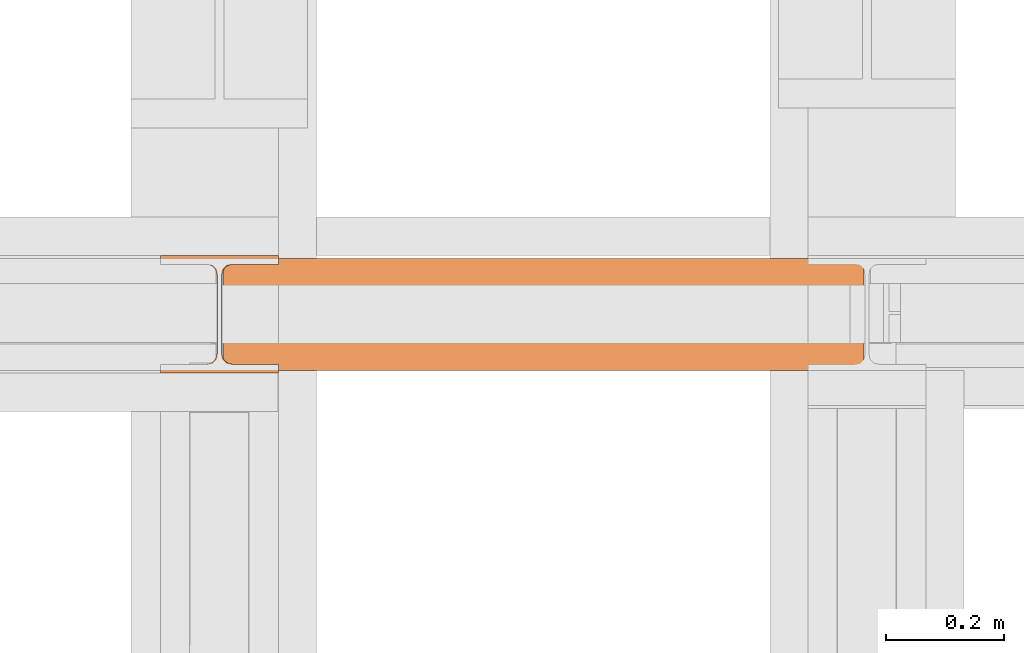
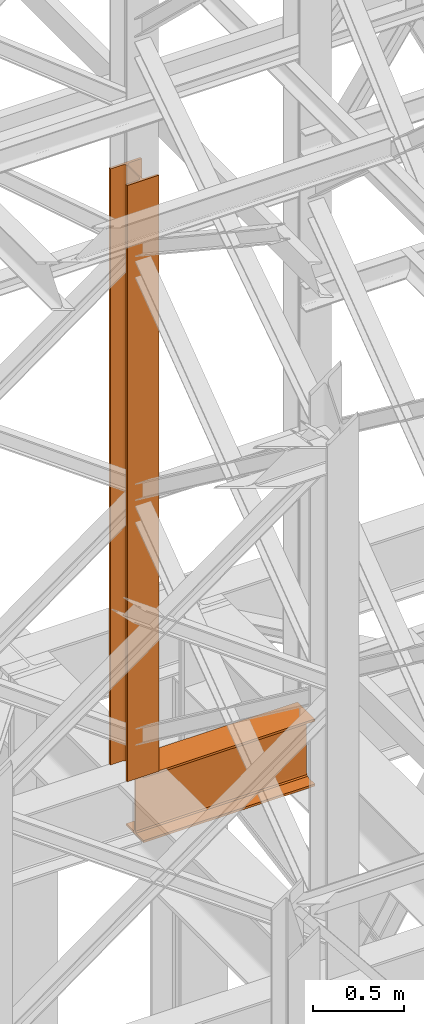
# One storey, part 129 of 208: 2 proxies.
"""IFC2X3 building model written with IfcOpenShell, lengths in millimetres."""

import ifcopenshell
import ifcopenshell.guid

model = None  # the IFC model being written
_history = None  # IfcOwnerHistory: only IFC2X3 demands one
_inside = {}  # id of a spatial element -> (the spatial element, [elements in it])
_under = {}  # id of a project, library or spatial element -> (it, [spatial elements below it])
_declared = {}  # id of a project -> (the project, [libraries it declares])
_typed = {}  # id of a type object -> (the type object, [elements of that type])
_made_of = {}  # id of a material, layer set ... -> (it, [elements and type objects made of it])


def new_model(schema):
    """Start an empty IFC model of exactly this schema.

    Asked for "IFC4X3", IfcOpenShell would pick the latest addendum, in which some entities
    have other attributes; the version numbers below select the first issue.
    IFC2X3 requires an IfcOwnerHistory on every rooted entity: one is made here for all.
    """
    global model, _history
    if schema == "IFC4X3":
        model = ifcopenshell.file(schema_version=(4, 3, 0, 0))
    else:
        model = ifcopenshell.file(schema=schema)
    _inside.clear()
    _under.clear()
    _declared.clear()
    _typed.clear()
    _made_of.clear()
    _history = None
    if model.schema == "IFC2X3":
        org = make("IfcOrganization", Name="unknown")
        user = make(
            "IfcPersonAndOrganization",
            ThePerson=make("IfcPerson", FamilyName="unknown"),
            TheOrganization=org,
        )
        app = make(
            "IfcApplication",
            ApplicationDeveloper=org,
            Version="unknown",
            ApplicationFullName="unknown",
            ApplicationIdentifier="unknown",
        )
        _history = make(
            "IfcOwnerHistory",
            OwningUser=user,
            OwningApplication=app,
            ChangeAction="ADDED",
            CreationDate=0,
        )
    return model


def make(cls, **values):
    """One entity of the class cls with the attributes given. An attribute that is None is left unset."""
    return model.create_entity(
        cls, **{name: value for name, value in values.items() if value is not None}
    )


def entity(cls, *values):
    """Any entity or typed value of the class cls, its attributes in the order of the schema. None: left unset."""
    e = model.create_entity(cls)
    for i, value in enumerate(values):
        if value is not None:
            e[i] = value
    return e


def rooted(cls, **values):
    """An entity with a GlobalId (a new one), such as an element, a storey or a relation."""
    return make(cls, GlobalId=ifcopenshell.guid.new(), OwnerHistory=_history, **values)


def si_unit(unit_type, name, prefix=None):
    """IfcSIUnit, for example si_unit("LENGTHUNIT", "METRE", prefix="MILLI")."""
    return make("IfcSIUnit", UnitType=unit_type, Prefix=prefix, Name=name)


def converted_unit(unit_type, name, factor, base, dimensions=None, offset=None):
    """IfcConversionBasedUnit, such as the inch: factor (a typed value) times the base unit."""
    return make(
        "IfcConversionBasedUnit"
        if offset is None
        else "IfcConversionBasedUnitWithOffset",
        ConversionOffset=offset,
        Dimensions=None
        if dimensions is None
        else entity("IfcDimensionalExponents", *dimensions),
        UnitType=unit_type,
        Name=name,
        ConversionFactor=make(
            "IfcMeasureWithUnit", ValueComponent=factor, UnitComponent=base
        ),
    )


def assignment(units):
    """IfcUnitAssignment: the units of a project."""
    return None if units is None else make("IfcUnitAssignment", Units=units)


def point(xyz):
    """IfcCartesianPoint."""
    return None if xyz is None else make("IfcCartesianPoint", Coordinates=xyz)


def direction(xyz):
    """IfcDirection."""
    return None if xyz is None else make("IfcDirection", DirectionRatios=xyz)


def frame(location, z_axis=None, x_axis=None):
    """IfcAxis2Placement3D, a coordinate frame: its origin and axes. An axis left out is left unset."""
    return make(
        "IfcAxis2Placement3D",
        Location=point(location),
        Axis=direction(z_axis),
        RefDirection=direction(x_axis),
    )


def origin():
    """The frame at (0, 0, 0) with its axes left unset."""
    return frame((0.0, 0.0, 0.0))


def origin_with_axes():
    """The frame at (0, 0, 0) with the z axis (0, 0, 1) and the x axis (1, 0, 0) written out."""
    return frame((0.0, 0.0, 0.0), z_axis=(0.0, 0.0, 1.0), x_axis=(1.0, 0.0, 0.0))


def place(relative_to, where):
    """IfcLocalPlacement: puts the frame where relative to a parent placement (None: the world)."""
    return make(
        "IfcLocalPlacement", PlacementRelTo=relative_to, RelativePlacement=where
    )


def context(
    kind, dimensions, precision=None, world=None, true_north=None, identifier=None
):
    """IfcGeometricRepresentationContext, for example the 3D "Model" context."""
    return make(
        "IfcGeometricRepresentationContext",
        ContextIdentifier=identifier,
        ContextType=kind,
        CoordinateSpaceDimension=dimensions,
        Precision=precision,
        WorldCoordinateSystem=world,
        TrueNorth=true_north,
    )


def subcontext(parent, identifier, kind, view, scale=None):
    """IfcGeometricRepresentationSubContext, for example "Body" below "Model"."""
    return make(
        "IfcGeometricRepresentationSubContext",
        ContextIdentifier=identifier,
        ContextType=kind,
        ParentContext=parent,
        TargetScale=scale,
        TargetView=view,
    )


def project(units=None, contexts=None):
    """IfcProject with its units and contexts."""
    return rooted(
        "IfcProject",
        Name="project",
        RepresentationContexts=contexts,
        UnitsInContext=assignment(units),
    )


def spatial(cls, under=None, at=None, **own):
    """A site, building, storey or space (cls), placed at a placement, below another one or the project."""
    s = rooted(cls, ObjectPlacement=at, **own)
    if under is not None:
        _under.setdefault(under.id(), (under, []))[1].append(s)
    return s


def faces_of(points, faces, orient=None, outer=None):
    """IfcFace entities. A face is a list of loops; a loop is a list of indices into points, from 0.

    orient and outer hold one flag for each loop. By default every Orientation is true, the
    first loop of a face is its IfcFaceOuterBound and the others are IfcFaceBound.
    """
    made = []
    for i, loops in enumerate(faces):
        bounds = []
        for j, loop in enumerate(loops):
            is_outer = j == 0 if outer is None else outer[i][j]
            bounds.append(
                make(
                    "IfcFaceOuterBound" if is_outer else "IfcFaceBound",
                    Bound=make("IfcPolyLoop", Polygon=[points[k] for k in loop]),
                    Orientation=True if orient is None else orient[i][j],
                )
            )
        made.append(make("IfcFace", Bounds=bounds))
    return made


def faceted_brep(points, faces, orient=None, outer=None, voids=None):
    """IfcFacetedBrep: a solid bounded by flat faces; with voids (closed shells), ...WithVoids."""
    shared = [point(p) for p in points]
    hull = make("IfcClosedShell", CfsFaces=faces_of(shared, faces, orient, outer))
    if voids is None:
        return make("IfcFacetedBrep", Outer=hull)
    return make(
        "IfcFacetedBrepWithVoids",
        Outer=hull,
        Voids=[
            make(cls, CfsFaces=faces_of(shared, fs, o, b)) for cls, fs, o, b in voids
        ],
    )


def shape(context_of_items, identifier, shape_type, items):
    """IfcShapeRepresentation: the items that make up one representation, for example the "Body"."""
    return make(
        "IfcShapeRepresentation",
        ContextOfItems=context_of_items,
        RepresentationIdentifier=identifier,
        RepresentationType=shape_type,
        Items=items,
    )


def made_of(thing, what):
    """Note that an element or type object is made of a material, layer set ...; save() writes the relation."""
    if what is not None:
        _made_of.setdefault(what.id(), (what, []))[1].append(thing)
    return thing


def element(
    cls,
    number,
    at=None,
    inside=None,
    cuts=None,
    type_object=None,
    material=None,
    context=None,
    identifier="Body",
    shape_type=None,
    held_by="IfcProductDefinitionShape",
    body=None,
    shapes=None,
    **own,
):
    """One element of the class cls, such as IfcWall. Its Tag is "e" and its number.

    at: its placement. inside: the storey or other place that contains it. cuts: it is an
    opening in that element (IfcRelVoidsElement). A single representation is given by context,
    identifier, shape_type and body (its items); several are given by shapes. held_by: the class
    of the entity that holds the representations. save() writes the other relations.
    """
    e = rooted(cls, Tag="e%d" % number, ObjectPlacement=at, **own)
    if body is not None:
        shapes = [shape(context, identifier, shape_type, body)]
    if shapes is not None:
        e.Representation = make(held_by, Representations=shapes)
    if inside is not None:
        _inside.setdefault(inside.id(), (inside, []))[1].append(e)
    if cuts is not None:
        rooted(
            "IfcRelVoidsElement", RelatingBuildingElement=cuts, RelatedOpeningElement=e
        )
    if type_object is not None:
        _typed.setdefault(type_object.id(), (type_object, []))[1].append(e)
    return made_of(e, material)


def aggregate(whole, parts):
    """IfcRelAggregates: a whole, such as a stair, and the parts it consists of."""
    return rooted("IfcRelAggregates", RelatingObject=whole, RelatedObjects=parts)


def save(model, path):
    """Write the relations noted so far, then the file.

    IfcRelAggregates (storeys below a building ...), IfcRelContainedInSpatialStructure (elements
    in a storey), IfcRelDefinesByType, IfcRelAssociatesMaterial and IfcRelDeclares: one each for
    every whole, place, type object, material and project.
    """
    for whole, parts in _under.values():
        aggregate(whole, parts)
    for where, things in _inside.values():
        rooted(
            "IfcRelContainedInSpatialStructure",
            RelatedElements=things,
            RelatingStructure=where,
        )
    for kind, things in _typed.values():
        rooted("IfcRelDefinesByType", RelatedObjects=things, RelatingType=kind)
    for what, things in _made_of.values():
        rooted("IfcRelAssociatesMaterial", RelatedObjects=things, RelatingMaterial=what)
    for by, libraries in _declared.values():
        rooted("IfcRelDeclares", RelatingContext=by, RelatedDefinitions=libraries)
    model.write(path)


model = new_model("IFC2X3")

# Units and contexts
model_context = context("Model", 3, precision=1e-05, world=origin())
plan_context = context("Plan", 3, precision=1e-05, world=origin())
body_context = subcontext(model_context, "Body", "Model", "MODEL_VIEW")
ifc_project = project(units=[si_unit("LENGTHUNIT", "METRE", prefix="MILLI"), converted_unit("PLANEANGLEUNIT", "DEGREE", entity("IfcPlaneAngleMeasure", 0.0174532925199433), si_unit("PLANEANGLEUNIT", "RADIAN"), dimensions=[0, 0, 0, 0, 0, 0, 0]), si_unit("AREAUNIT", "SQUARE_METRE"), si_unit("VOLUMEUNIT", "CUBIC_METRE")], contexts=[model_context, plan_context])

# Building, storey
building_placement = place(None, origin())
building = spatial("IfcBuilding", under=ifc_project, at=building_placement, CompositionType="COMPLEX")
storey_placement = place(building_placement, origin_with_axes())
storey = spatial("IfcBuildingStorey", under=building, at=storey_placement, Name="Geschoss", CompositionType="ELEMENT")

# Proxies
proxy_1_placement = place(storey_placement, frame((2199.254968580824, -13857.57439657637, 4834.989987483023), z_axis=(0.0, 0.0, 1.0), x_axis=(1.0, 0.0, 0.0)))
element("IfcBuildingElementProxy", 1, at=proxy_1_placement, inside=storey, context=body_context, shape_type="Brep", body=[
    faceted_brep([(1088.009999895696, 0.01000000000021828, 450.0100178813937), (1088.009999895696, 190.0100125169756, 450.0100178813937), (1088.009999895696, 190.0100125169756, 435.4100240564349), (1088.009999895696, 120.7100073045494, 435.4100091552737), (1088.009999895696, 109.841562265754, 433.2347078418734), (1088.009999895696, 101.8853126263621, 425.2784563398363), (1088.009999895696, 99.71000619068764, 414.4100113010409), (1088.009999895696, 99.71000619068764, 35.60999167919181), (1088.009999895696, 101.8853126263621, 24.74154664039634), (1088.009999895696, 109.841562265754, 16.78529513835929), (1088.009999895696, 120.7100073045494, 14.60999382495902), (1088.009999895696, 190.0100125169756, 14.60999382495902), (1088.009999895696, 190.0100125169756, 0.01000000000021828), (1088.009999895696, 0.01000000000021828, 0.01000000000021828), (1088.009999895696, 0.01000000000021828, 14.60999382495902), (1088.009999895696, 69.3100052124264, 14.60999382495902), (1088.009999895696, 80.17845025122188, 16.78529513835929), (1088.009999895696, 88.13469989061377, 24.74154664039634), (1088.009999895696, 90.3100063262882, 35.60999167919181), (1088.009999895696, 90.3100063262882, 414.4100113010409), (1088.009999895696, 88.13469989061377, 425.2784563398363), (1088.009999895696, 80.17845025122188, 433.2347078418734), (1088.009999895696, 69.3100052124264, 435.4100091552737), (1088.009999895696, 0.01000000000021828, 435.4100240564349), (1088.009999895696, 190.0100125169756, 450.0100178813937), (1088.009999895696, 0.01000000000021828, 450.0100178813937), (0.01000000000021828, 0.01000000000021828, 450.0100178813937), (0.01000000000021828, 190.0100125169756, 450.0100178813937), (1088.009999895696, 190.0100125169756, 435.4100240564349), (1088.009999895696, 190.0100125169756, 450.0100178813937), (0.01000000000021828, 190.0100125169756, 450.0100178813937), (0.01000000000021828, 190.0100125169756, 435.4100240564349), (1088.009999895696, 120.7100073045494, 435.4100091552737), (1088.009999895696, 190.0100125169756, 435.4100240564349), (0.01000000000021828, 190.0100125169756, 435.4100240564349), (0.01000000000021828, 120.7100073045494, 435.4100091552737), (1088.009999895696, 109.841562265754, 433.2347078418734), (1088.009999895696, 120.7100073045494, 435.4100091552737), (0.01000000000021828, 120.7100073045494, 435.4100091552737), (0.01000000000021828, 109.841562265754, 433.2347078418734), (1088.009999895696, 101.8853126263621, 425.2784563398363), (1088.009999895696, 109.841562265754, 433.2347078418734), (0.01000000000021828, 109.841562265754, 433.2347078418734), (0.01000000000021828, 101.8853126263621, 425.2784563398363), (1088.009999895696, 99.71000619068764, 414.4100113010409), (1088.009999895696, 101.8853126263621, 425.2784563398363), (0.01000000000021828, 101.8853126263621, 425.2784563398363), (0.01000000000021828, 99.71000619068764, 414.4100113010409), (1088.009999895696, 99.71000619068764, 35.60999167919181), (1088.009999895696, 99.71000619068764, 414.4100113010409), (0.01000000000021828, 99.71000619068764, 414.4100113010409), (0.01000000000021828, 99.71000619068764, 35.60999167919181), (1088.009999895696, 101.8853126263621, 24.74154664039634), (1088.009999895696, 99.71000619068764, 35.60999167919181), (0.01000000000021828, 99.71000619068764, 35.60999167919181), (0.01000000000021828, 101.8853126263621, 24.74154664039634), (1088.009999895696, 109.841562265754, 16.78529513835929), (1088.009999895696, 101.8853126263621, 24.74154664039634), (0.01000000000021828, 101.8853126263621, 24.74154664039634), (0.01000000000021828, 109.841562265754, 16.78529513835929), (1088.009999895696, 120.7100073045494, 14.60999382495902), (1088.009999895696, 109.841562265754, 16.78529513835929), (0.01000000000021828, 109.841562265754, 16.78529513835929), (0.01000000000021828, 120.7100073045494, 14.60999382495902), (1088.009999895696, 190.0100125169756, 14.60999382495902), (1088.009999895696, 120.7100073045494, 14.60999382495902), (0.01000000000021828, 120.7100073045494, 14.60999382495902), (0.01000000000021828, 190.0100125169756, 14.60999382495902), (1088.009999895696, 190.0100125169756, 0.01000000000021828), (1088.009999895696, 190.0100125169756, 14.60999382495902), (0.01000000000021828, 190.0100125169756, 14.60999382495902), (0.01000000000021828, 190.0100125169756, 0.01000000000021828), (1088.009999895696, 0.01000000000021828, 0.01000000000021828), (1088.009999895696, 190.0100125169756, 0.01000000000021828), (0.01000000000021828, 190.0100125169756, 0.01000000000021828), (0.01000000000021828, 0.01000000000021828, 0.01000000000021828), (1088.009999895696, 0.01000000000021828, 14.60999382495902), (1088.009999895696, 0.01000000000021828, 0.01000000000021828), (0.01000000000021828, 0.01000000000021828, 0.01000000000021828), (0.01000000000021828, 0.01000000000021828, 14.60999382495902), (1088.009999895696, 69.3100052124264, 14.60999382495902), (1088.009999895696, 0.01000000000021828, 14.60999382495902), (0.01000000000021828, 0.01000000000021828, 14.60999382495902), (0.01000000000021828, 69.3100052124264, 14.60999382495902), (1088.009999895696, 80.17845025122188, 16.78529513835929), (1088.009999895696, 69.3100052124264, 14.60999382495902), (0.01000000000021828, 69.3100052124264, 14.60999382495902), (0.01000000000021828, 80.17845025122188, 16.78529513835929), (1088.009999895696, 88.13469989061377, 24.74154664039634), (1088.009999895696, 80.17845025122188, 16.78529513835929), (0.01000000000021828, 80.17845025122188, 16.78529513835929), (0.01000000000021828, 88.13469989061377, 24.74154664039634), (1088.009999895696, 90.3100063262882, 35.60999167919181), (1088.009999895696, 88.13469989061377, 24.74154664039634), (0.01000000000021828, 88.13469989061377, 24.74154664039634), (0.01000000000021828, 90.3100063262882, 35.60999167919181), (1088.009999895696, 90.3100063262882, 414.4100113010409), (1088.009999895696, 90.3100063262882, 35.60999167919181), (0.01000000000021828, 90.3100063262882, 35.60999167919181), (0.01000000000021828, 90.3100063262882, 414.4100113010409), (1088.009999895696, 88.13469989061377, 425.2784563398363), (1088.009999895696, 90.3100063262882, 414.4100113010409), (0.01000000000021828, 90.3100063262882, 414.4100113010409), (0.01000000000021828, 88.13469989061377, 425.2784563398363), (1088.009999895696, 80.17845025122188, 433.2347078418734), (1088.009999895696, 88.13469989061377, 425.2784563398363), (0.01000000000021828, 88.13469989061377, 425.2784563398363), (0.01000000000021828, 80.17845025122188, 433.2347078418734), (1088.009999895696, 69.3100052124264, 435.4100091552737), (1088.009999895696, 80.17845025122188, 433.2347078418734), (0.01000000000021828, 80.17845025122188, 433.2347078418734), (0.01000000000021828, 69.3100052124264, 435.4100091552737), (1088.009999895696, 0.01000000000021828, 435.4100240564349), (1088.009999895696, 69.3100052124264, 435.4100091552737), (0.01000000000021828, 69.3100052124264, 435.4100091552737), (0.01000000000021828, 0.01000000000021828, 435.4100240564349), (1088.009999895696, 0.01000000000021828, 450.0100178813937), (1088.009999895696, 0.01000000000021828, 435.4100240564349), (0.01000000000021828, 0.01000000000021828, 435.4100240564349), (0.01000000000021828, 0.01000000000021828, 450.0100178813937), (0.01000000000021828, 0.01000000000021828, 450.0100178813937), (0.01000000000021828, 0.01000000000021828, 435.4100240564349), (0.01000000000021828, 69.3100052124264, 435.4100091552737), (0.01000000000021828, 80.17845025122188, 433.2347078418734), (0.01000000000021828, 88.13469989061377, 425.2784563398363), (0.01000000000021828, 90.3100063262882, 414.4100113010409), (0.01000000000021828, 90.3100063262882, 35.60999167919181), (0.01000000000021828, 88.13469989061377, 24.74154664039634), (0.01000000000021828, 80.17845025122188, 16.78529513835929), (0.01000000000021828, 69.3100052124264, 14.60999382495902), (0.01000000000021828, 0.01000000000021828, 14.60999382495902), (0.01000000000021828, 0.01000000000021828, 0.01000000000021828), (0.01000000000021828, 190.0100125169756, 0.01000000000021828), (0.01000000000021828, 190.0100125169756, 14.60999382495902), (0.01000000000021828, 120.7100073045494, 14.60999382495902), (0.01000000000021828, 109.841562265754, 16.78529513835929), (0.01000000000021828, 101.8853126263621, 24.74154664039634), (0.01000000000021828, 99.71000619068764, 35.60999167919181), (0.01000000000021828, 99.71000619068764, 414.4100113010409), (0.01000000000021828, 101.8853126263621, 425.2784563398363), (0.01000000000021828, 109.841562265754, 433.2347078418734), (0.01000000000021828, 120.7100073045494, 435.4100091552737), (0.01000000000021828, 190.0100125169756, 435.4100240564349), (0.01000000000021828, 190.0100125169756, 450.0100178813937)], [[[0, 1, 2, 3, 4, 5, 6, 7, 8, 9, 10, 11, 12, 13, 14, 15, 16, 17, 18, 19, 20, 21, 22, 23]], [[24, 25, 26, 27]], [[28, 29, 30, 31]], [[32, 33, 34, 35]], [[36, 37, 38, 39]], [[40, 41, 42, 43]], [[44, 45, 46, 47]], [[48, 49, 50, 51]], [[52, 53, 54, 55]], [[56, 57, 58, 59]], [[60, 61, 62, 63]], [[64, 65, 66, 67]], [[68, 69, 70, 71]], [[72, 73, 74, 75]], [[76, 77, 78, 79]], [[80, 81, 82, 83]], [[84, 85, 86, 87]], [[88, 89, 90, 91]], [[92, 93, 94, 95]], [[96, 97, 98, 99]], [[100, 101, 102, 103]], [[104, 105, 106, 107]], [[108, 109, 110, 111]], [[112, 113, 114, 115]], [[116, 117, 118, 119]], [[120, 121, 122, 123, 124, 125, 126, 127, 128, 129, 130, 131, 132, 133, 134, 135, 136, 137, 138, 139, 140, 141, 142, 143]]], orient=[[False], [False], [False], [False], [False], [False], [False], [False], [False], [False], [False], [False], [False], [False], [False], [False], [False], [False], [False], [False], [False], [False], [False], [False], [False], [False]]),
])
proxy_2_placement = place(storey_placement, frame((2093.254968528665, -13862.57439031789, 5284.990005364414), z_axis=(0.0, 0.0, 1.0), x_axis=(1.0, 0.0, 0.0)))
element("IfcBuildingElementProxy", 2, at=proxy_2_placement, inside=storey, Name="3D Element", context=body_context, shape_type="Brep", body=[
    faceted_brep([(0.01000000000021828, 15.01000000000022, 0.01000000000021828), (0.01000000000021828, 0.01000000000021828, 0.01000000000021828), (200.0100000000002, 0.01000000000021828, 0.01000000000021828), (200.0100000000002, 15.01000000000022, 0.01000000000021828), (122.5100000000002, 15.01000000000022, 0.01000000000021828), (116.9477129694265, 15.8910440384916, 0.01000000000021828), (111.9298832894656, 18.44771635773031, 0.01000000000021828), (107.9477163577321, 22.42988328946558, 0.01000000000021828), (105.3910440384934, 27.44771296942599, 0.01000000000021828), (104.5100000000002, 33.01000000000022, 0.01000000000021828), (104.5100000000002, 167.0100000000002, 0.01000000000021828), (105.6055874411059, 172.9933586889038, 0.01000000000021828), (107.9477163577321, 177.5901167105349, 0.01000000000021828), (111.9298832894656, 181.5722836422665, 0.01000000000021828), (116.9477129694265, 184.1289559615052, 0.01000000000021828), (122.5100000000002, 185.0100000000002, 0.01000000000021828), (200.0100000000002, 185.0100000000002, 0.01000000000021828), (200.0100000000002, 200.0100000000002, 0.01000000000021828), (0.01000000000021828, 200.0100000000002, 0.01000000000021828), (0.01000000000021828, 185.0100000000002, 0.01000000000021828), (77.51000000000022, 185.0100000000002, 0.01000000000021828), (83.07228703057353, 184.1289559615052, 0.01000000000021828), (88.0901167105344, 181.5722836422665, 0.01000000000021828), (92.07228364226785, 177.5901167105349, 0.01000000000021828), (94.62895596150656, 172.5722870305744, 0.01000000000021828), (95.51000000000022, 167.0100000000002, 0.01000000000021828), (95.51000000000022, 33.01000000000022, 0.01000000000021828), (94.62895596150656, 27.44771296942599, 0.01000000000021828), (92.07228364226785, 22.42988328946558, 0.01000000000021828), (88.0901167105344, 18.44771635773031, 0.01000000000021828), (83.07228703057353, 15.8910440384916, 0.01000000000021828), (77.51000000000022, 15.01000000000022, 0.01000000000021828), (0.01000000000021828, 0.01000000000021828, 0.01000000000021828), (0.01000000000021828, 15.01000000000022, 0.01000000000021828), (0.01000000000021828, 15.01000000000022, 4000.01), (0.01000000000021828, 0.01000000000021828, 4000.01), (200.0100000000002, 0.01000000000021828, 0.01000000000021828), (0.01000000000021828, 0.01000000000021828, 0.01000000000021828), (0.01000000000021828, 0.01000000000021828, 4000.01), (200.0100000000002, 0.01000000000021828, 4000.01), (200.0100000000002, 15.01000000000022, 0.01000000000021828), (200.0100000000002, 0.01000000000021828, 0.01000000000021828), (200.0100000000002, 0.01000000000021828, 4000.01), (200.0100000000002, 15.01000000000022, 4000.01), (122.5100000000002, 15.01000000000022, 0.01000000000021828), (200.0100000000002, 15.01000000000022, 0.01000000000021828), (200.0100000000002, 15.01000000000022, 4000.01), (122.5100000000002, 15.01000000000022, 4000.01), (116.9477129694265, 15.8910440384916, 0.01000000000021828), (122.5100000000002, 15.01000000000022, 0.01000000000021828), (122.5100000000002, 15.01000000000022, 4000.01), (116.9477129694265, 15.8910440384916, 4000.01), (111.9298832894656, 18.44771635773031, 0.01000000000021828), (116.9477129694265, 15.8910440384916, 0.01000000000021828), (116.9477129694265, 15.8910440384916, 4000.01), (111.9298832894656, 18.44771635773031, 4000.01), (107.9477163577321, 22.42988328946558, 0.01000000000021828), (111.9298832894656, 18.44771635773031, 0.01000000000021828), (111.9298832894656, 18.44771635773031, 4000.01), (107.9477163577321, 22.42988328946558, 4000.01), (105.3910440384934, 27.44771296942599, 0.01000000000021828), (107.9477163577321, 22.42988328946558, 0.01000000000021828), (107.9477163577321, 22.42988328946558, 4000.01), (105.3910440384934, 27.44771296942599, 4000.01), (104.5100000000002, 33.01000000000022, 0.01000000000021828), (105.3910440384934, 27.44771296942599, 0.01000000000021828), (105.3910440384934, 27.44771296942599, 4000.01), (104.5100000000002, 33.01000000000022, 4000.01), (104.5100000000002, 167.0100000000002, 0.01000000000021828), (104.5100000000002, 33.01000000000022, 0.01000000000021828), (104.5100000000002, 33.01000000000022, 4000.01), (104.5100000000002, 167.0100000000002, 4000.01), (105.6055874411059, 172.9933586889038, 0.01000000000021828), (104.5100000000002, 167.0100000000002, 0.01000000000021828), (104.5100000000002, 167.0100000000002, 4000.01), (105.6055874411059, 172.9933586889038, 4000.01), (107.9477163577321, 177.5901167105349, 0.01000000000021828), (105.6055874411059, 172.9933586889038, 0.01000000000021828), (105.6055874411059, 172.9933586889038, 4000.01), (107.9477163577321, 177.5901167105349, 4000.01), (111.9298832894656, 181.5722836422665, 0.01000000000021828), (107.9477163577321, 177.5901167105349, 0.01000000000021828), (107.9477163577321, 177.5901167105349, 4000.01), (111.9298832894656, 181.5722836422665, 4000.01), (116.9477129694265, 184.1289559615052, 0.01000000000021828), (111.9298832894656, 181.5722836422665, 0.01000000000021828), (111.9298832894656, 181.5722836422665, 4000.01), (116.9477129694265, 184.1289559615052, 4000.01), (122.5100000000002, 185.0100000000002, 0.01000000000021828), (116.9477129694265, 184.1289559615052, 0.01000000000021828), (116.9477129694265, 184.1289559615052, 4000.01), (122.5100000000002, 185.0100000000002, 4000.01), (200.0100000000002, 185.0100000000002, 0.01000000000021828), (122.5100000000002, 185.0100000000002, 0.01000000000021828), (122.5100000000002, 185.0100000000002, 4000.01), (200.0100000000002, 185.0100000000002, 4000.01), (200.0100000000002, 200.0100000000002, 0.01000000000021828), (200.0100000000002, 185.0100000000002, 0.01000000000021828), (200.0100000000002, 185.0100000000002, 4000.01), (200.0100000000002, 200.0100000000002, 4000.01), (0.01000000000021828, 200.0100000000002, 0.01000000000021828), (200.0100000000002, 200.0100000000002, 0.01000000000021828), (200.0100000000002, 200.0100000000002, 4000.01), (0.01000000000021828, 200.0100000000002, 4000.01), (0.01000000000021828, 185.0100000000002, 0.01000000000021828), (0.01000000000021828, 200.0100000000002, 0.01000000000021828), (0.01000000000021828, 200.0100000000002, 4000.01), (0.01000000000021828, 185.0100000000002, 4000.01), (77.51000000000022, 185.0100000000002, 0.01000000000021828), (0.01000000000021828, 185.0100000000002, 0.01000000000021828), (0.01000000000021828, 185.0100000000002, 4000.01), (77.51000000000022, 185.0100000000002, 4000.01), (83.07228703057353, 184.1289559615052, 0.01000000000021828), (77.51000000000022, 185.0100000000002, 0.01000000000021828), (77.51000000000022, 185.0100000000002, 4000.01), (83.07228703057353, 184.1289559615052, 4000.01), (88.0901167105344, 181.5722836422665, 0.01000000000021828), (83.07228703057353, 184.1289559615052, 0.01000000000021828), (83.07228703057353, 184.1289559615052, 4000.01), (88.0901167105344, 181.5722836422665, 4000.01), (92.07228364226785, 177.5901167105349, 0.01000000000021828), (88.0901167105344, 181.5722836422665, 0.01000000000021828), (88.0901167105344, 181.5722836422665, 4000.01), (92.07228364226785, 177.5901167105349, 4000.01), (94.62895596150656, 172.5722870305744, 0.01000000000021828), (92.07228364226785, 177.5901167105349, 0.01000000000021828), (92.07228364226785, 177.5901167105349, 4000.01), (94.62895596150656, 172.5722870305744, 4000.01), (95.51000000000022, 167.0100000000002, 0.01000000000021828), (94.62895596150656, 172.5722870305744, 0.01000000000021828), (94.62895596150656, 172.5722870305744, 4000.01), (95.51000000000022, 167.0100000000002, 4000.01), (95.51000000000022, 33.01000000000022, 0.01000000000021828), (95.51000000000022, 167.0100000000002, 0.01000000000021828), (95.51000000000022, 167.0100000000002, 4000.01), (95.51000000000022, 33.01000000000022, 4000.01), (94.62895596150656, 27.44771296942599, 0.01000000000021828), (95.51000000000022, 33.01000000000022, 0.01000000000021828), (95.51000000000022, 33.01000000000022, 4000.01), (94.62895596150656, 27.44771296942599, 4000.01), (92.07228364226785, 22.42988328946558, 0.01000000000021828), (94.62895596150656, 27.44771296942599, 0.01000000000021828), (94.62895596150656, 27.44771296942599, 4000.01), (92.07228364226785, 22.42988328946558, 4000.01), (88.0901167105344, 18.44771635773031, 0.01000000000021828), (92.07228364226785, 22.42988328946558, 0.01000000000021828), (92.07228364226785, 22.42988328946558, 4000.01), (88.0901167105344, 18.44771635773031, 4000.01), (83.07228703057353, 15.8910440384916, 0.01000000000021828), (88.0901167105344, 18.44771635773031, 0.01000000000021828), (88.0901167105344, 18.44771635773031, 4000.01), (83.07228703057353, 15.8910440384916, 4000.01), (77.51000000000022, 15.01000000000022, 0.01000000000021828), (83.07228703057353, 15.8910440384916, 0.01000000000021828), (83.07228703057353, 15.8910440384916, 4000.01), (77.51000000000022, 15.01000000000022, 4000.01), (0.01000000000021828, 15.01000000000022, 0.01000000000021828), (77.51000000000022, 15.01000000000022, 0.01000000000021828), (77.51000000000022, 15.01000000000022, 4000.01), (0.01000000000021828, 15.01000000000022, 4000.01), (0.01000000000021828, 15.01000000000022, 4000.01), (77.51000000000022, 15.01000000000022, 4000.01), (83.07228703057353, 15.8910440384916, 4000.01), (88.0901167105344, 18.44771635773031, 4000.01), (92.07228364226785, 22.42988328946558, 4000.01), (94.62895596150656, 27.44771296942599, 4000.01), (95.51000000000022, 33.01000000000022, 4000.01), (95.51000000000022, 167.0100000000002, 4000.01), (94.62895596150656, 172.5722870305744, 4000.01), (92.07228364226785, 177.5901167105349, 4000.01), (88.0901167105344, 181.5722836422665, 4000.01), (83.07228703057353, 184.1289559615052, 4000.01), (77.51000000000022, 185.0100000000002, 4000.01), (0.01000000000021828, 185.0100000000002, 4000.01), (0.01000000000021828, 200.0100000000002, 4000.01), (200.0100000000002, 200.0100000000002, 4000.01), (200.0100000000002, 185.0100000000002, 4000.01), (122.5100000000002, 185.0100000000002, 4000.01), (116.9477129694265, 184.1289559615052, 4000.01), (111.9298832894656, 181.5722836422665, 4000.01), (107.9477163577321, 177.5901167105349, 4000.01), (105.6055874411059, 172.9933586889038, 4000.01), (104.5100000000002, 167.0100000000002, 4000.01), (104.5100000000002, 33.01000000000022, 4000.01), (105.3910440384934, 27.44771296942599, 4000.01), (107.9477163577321, 22.42988328946558, 4000.01), (111.9298832894656, 18.44771635773031, 4000.01), (116.9477129694265, 15.8910440384916, 4000.01), (122.5100000000002, 15.01000000000022, 4000.01), (200.0100000000002, 15.01000000000022, 4000.01), (200.0100000000002, 0.01000000000021828, 4000.01), (0.01000000000021828, 0.01000000000021828, 4000.01)], [[[0, 1, 2, 3, 4, 5, 6, 7, 8, 9, 10, 11, 12, 13, 14, 15, 16, 17, 18, 19, 20, 21, 22, 23, 24, 25, 26, 27, 28, 29, 30, 31]], [[32, 33, 34, 35]], [[36, 37, 38, 39]], [[40, 41, 42, 43]], [[44, 45, 46, 47]], [[48, 49, 50, 51]], [[52, 53, 54, 55]], [[56, 57, 58, 59]], [[60, 61, 62, 63]], [[64, 65, 66, 67]], [[68, 69, 70, 71]], [[72, 73, 74, 75]], [[76, 77, 78, 79]], [[80, 81, 82, 83]], [[84, 85, 86, 87]], [[88, 89, 90, 91]], [[92, 93, 94, 95]], [[96, 97, 98, 99]], [[100, 101, 102, 103]], [[104, 105, 106, 107]], [[108, 109, 110, 111]], [[112, 113, 114, 115]], [[116, 117, 118, 119]], [[120, 121, 122, 123]], [[124, 125, 126, 127]], [[128, 129, 130, 131]], [[132, 133, 134, 135]], [[136, 137, 138, 139]], [[140, 141, 142, 143]], [[144, 145, 146, 147]], [[148, 149, 150, 151]], [[152, 153, 154, 155]], [[156, 157, 158, 159]], [[160, 161, 162, 163, 164, 165, 166, 167, 168, 169, 170, 171, 172, 173, 174, 175, 176, 177, 178, 179, 180, 181, 182, 183, 184, 185, 186, 187, 188, 189, 190, 191]]], orient=[[False], [False], [False], [False], [False], [False], [False], [False], [False], [False], [False], [False], [False], [False], [False], [False], [False], [False], [False], [False], [False], [False], [False], [False], [False], [False], [False], [False], [False], [False], [False], [False], [False], [False]]),
])

save(model, "model.ifc")
